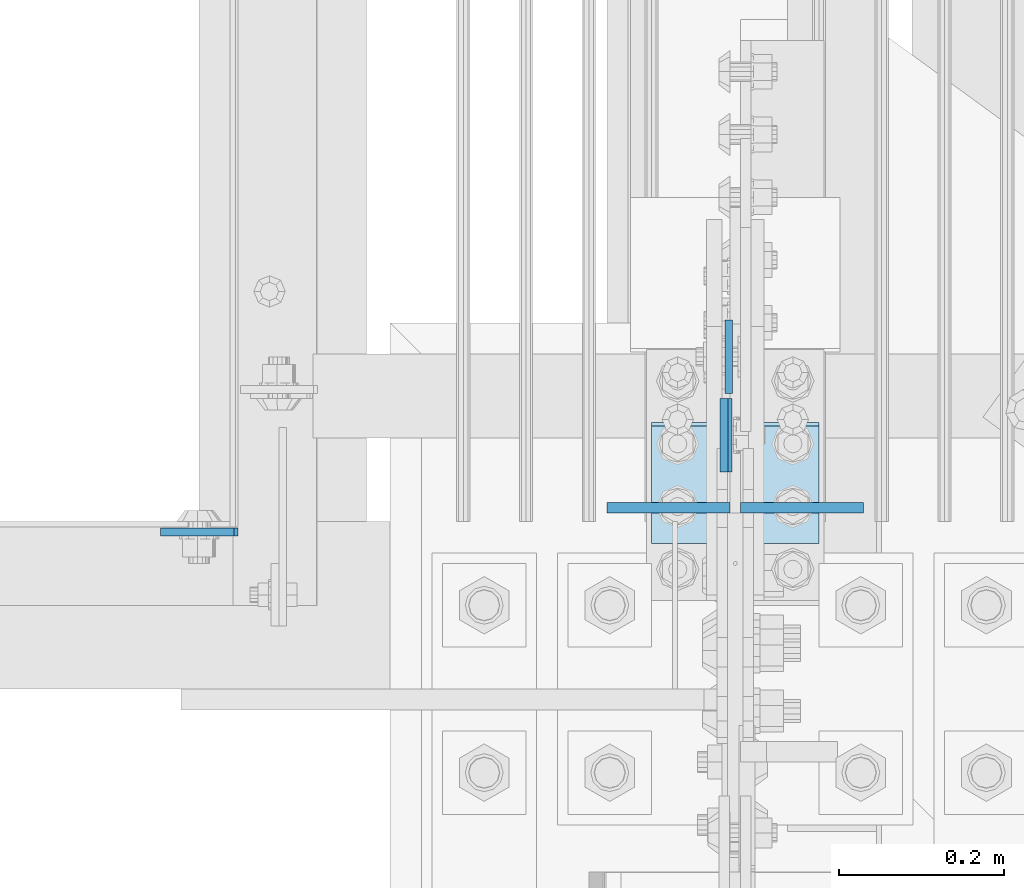
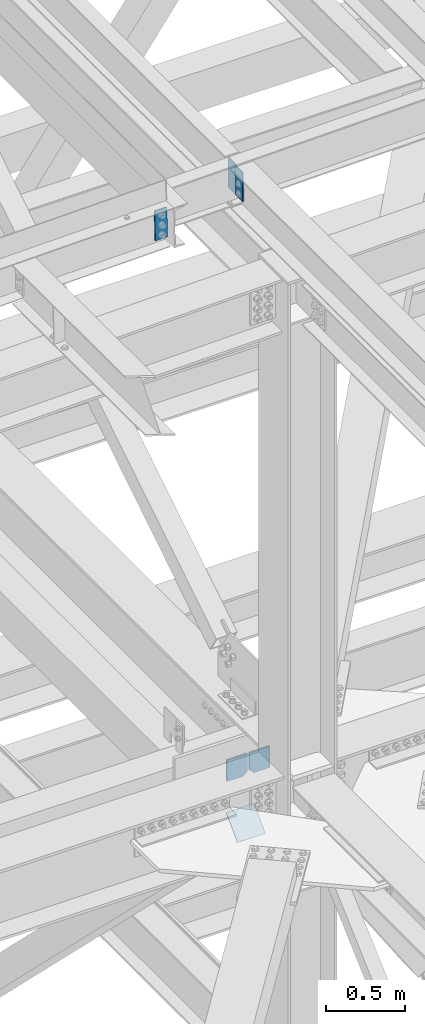
# One storey, part 3516 of 3843: 6 plates, 4 elements without a shape of their own.
"""IFC2X3 building model written with IfcOpenShell, lengths in millimetres."""

import ifcopenshell
import ifcopenshell.guid

model = None  # the IFC model being written
_history = None  # IfcOwnerHistory: only IFC2X3 demands one
_inside = {}  # id of a spatial element -> (the spatial element, [elements in it])
_under = {}  # id of a project, library or spatial element -> (it, [spatial elements below it])
_declared = {}  # id of a project -> (the project, [libraries it declares])
_typed = {}  # id of a type object -> (the type object, [elements of that type])
_made_of = {}  # id of a material, layer set ... -> (it, [elements and type objects made of it])


def new_model(schema):
    """Start an empty IFC model of exactly this schema.

    Asked for "IFC4X3", IfcOpenShell would pick the latest addendum, in which some entities
    have other attributes; the version numbers below select the first issue.
    IFC2X3 requires an IfcOwnerHistory on every rooted entity: one is made here for all.
    """
    global model, _history
    if schema == "IFC4X3":
        model = ifcopenshell.file(schema_version=(4, 3, 0, 0))
    else:
        model = ifcopenshell.file(schema=schema)
    _inside.clear()
    _under.clear()
    _declared.clear()
    _typed.clear()
    _made_of.clear()
    _history = None
    if model.schema == "IFC2X3":
        org = make("IfcOrganization", Name="unknown")
        user = make(
            "IfcPersonAndOrganization",
            ThePerson=make("IfcPerson", FamilyName="unknown"),
            TheOrganization=org,
        )
        app = make(
            "IfcApplication",
            ApplicationDeveloper=org,
            Version="unknown",
            ApplicationFullName="unknown",
            ApplicationIdentifier="unknown",
        )
        _history = make(
            "IfcOwnerHistory",
            OwningUser=user,
            OwningApplication=app,
            ChangeAction="ADDED",
            CreationDate=0,
        )
    return model


def make(cls, **values):
    """One entity of the class cls with the attributes given. An attribute that is None is left unset."""
    return model.create_entity(
        cls, **{name: value for name, value in values.items() if value is not None}
    )


def rooted(cls, **values):
    """An entity with a GlobalId (a new one), such as an element, a storey or a relation."""
    return make(cls, GlobalId=ifcopenshell.guid.new(), OwnerHistory=_history, **values)


def si_unit(unit_type, name, prefix=None):
    """IfcSIUnit, for example si_unit("LENGTHUNIT", "METRE", prefix="MILLI")."""
    return make("IfcSIUnit", UnitType=unit_type, Prefix=prefix, Name=name)


def assignment(units):
    """IfcUnitAssignment: the units of a project."""
    return None if units is None else make("IfcUnitAssignment", Units=units)


def point(xyz):
    """IfcCartesianPoint."""
    return None if xyz is None else make("IfcCartesianPoint", Coordinates=xyz)


def direction(xyz):
    """IfcDirection."""
    return None if xyz is None else make("IfcDirection", DirectionRatios=xyz)


def frame(location, z_axis=None, x_axis=None):
    """IfcAxis2Placement3D, a coordinate frame: its origin and axes. An axis left out is left unset."""
    return make(
        "IfcAxis2Placement3D",
        Location=point(location),
        Axis=direction(z_axis),
        RefDirection=direction(x_axis),
    )


def origin_with_axes():
    """The frame at (0, 0, 0) with the z axis (0, 0, 1) and the x axis (1, 0, 0) written out."""
    return frame((0.0, 0.0, 0.0), z_axis=(0.0, 0.0, 1.0), x_axis=(1.0, 0.0, 0.0))


def place(relative_to, where):
    """IfcLocalPlacement: puts the frame where relative to a parent placement (None: the world)."""
    return make(
        "IfcLocalPlacement", PlacementRelTo=relative_to, RelativePlacement=where
    )


def context(
    kind, dimensions, precision=None, world=None, true_north=None, identifier=None
):
    """IfcGeometricRepresentationContext, for example the 3D "Model" context."""
    return make(
        "IfcGeometricRepresentationContext",
        ContextIdentifier=identifier,
        ContextType=kind,
        CoordinateSpaceDimension=dimensions,
        Precision=precision,
        WorldCoordinateSystem=world,
        TrueNorth=true_north,
    )


def subcontext(parent, identifier, kind, view, scale=None):
    """IfcGeometricRepresentationSubContext, for example "Body" below "Model"."""
    return make(
        "IfcGeometricRepresentationSubContext",
        ContextIdentifier=identifier,
        ContextType=kind,
        ParentContext=parent,
        TargetScale=scale,
        TargetView=view,
    )


def project(units=None, contexts=None):
    """IfcProject with its units and contexts."""
    return rooted(
        "IfcProject",
        Name="project",
        RepresentationContexts=contexts,
        UnitsInContext=assignment(units),
    )


def spatial(cls, under=None, at=None, **own):
    """A site, building, storey or space (cls), placed at a placement, below another one or the project."""
    s = rooted(cls, ObjectPlacement=at, **own)
    if under is not None:
        _under.setdefault(under.id(), (under, []))[1].append(s)
    return s


def faces_of(points, faces, orient=None, outer=None):
    """IfcFace entities. A face is a list of loops; a loop is a list of indices into points, from 0.

    orient and outer hold one flag for each loop. By default every Orientation is true, the
    first loop of a face is its IfcFaceOuterBound and the others are IfcFaceBound.
    """
    made = []
    for i, loops in enumerate(faces):
        bounds = []
        for j, loop in enumerate(loops):
            is_outer = j == 0 if outer is None else outer[i][j]
            bounds.append(
                make(
                    "IfcFaceOuterBound" if is_outer else "IfcFaceBound",
                    Bound=make("IfcPolyLoop", Polygon=[points[k] for k in loop]),
                    Orientation=True if orient is None else orient[i][j],
                )
            )
        made.append(make("IfcFace", Bounds=bounds))
    return made


def faceted_brep(points, faces, orient=None, outer=None, voids=None):
    """IfcFacetedBrep: a solid bounded by flat faces; with voids (closed shells), ...WithVoids."""
    shared = [point(p) for p in points]
    hull = make("IfcClosedShell", CfsFaces=faces_of(shared, faces, orient, outer))
    if voids is None:
        return make("IfcFacetedBrep", Outer=hull)
    return make(
        "IfcFacetedBrepWithVoids",
        Outer=hull,
        Voids=[
            make(cls, CfsFaces=faces_of(shared, fs, o, b)) for cls, fs, o, b in voids
        ],
    )


def shape(context_of_items, identifier, shape_type, items):
    """IfcShapeRepresentation: the items that make up one representation, for example the "Body"."""
    return make(
        "IfcShapeRepresentation",
        ContextOfItems=context_of_items,
        RepresentationIdentifier=identifier,
        RepresentationType=shape_type,
        Items=items,
    )


def material(Name=None, Category=None):
    """IfcMaterial."""
    return make("IfcMaterial", Name=Name, Category=Category)


def made_of(thing, what):
    """Note that an element or type object is made of a material, layer set ...; save() writes the relation."""
    if what is not None:
        _made_of.setdefault(what.id(), (what, []))[1].append(thing)
    return thing


def type_object(cls, material=None, **own):
    """A type object (cls), such as IfcWallType, which elements share."""
    return made_of(rooted(cls, **own), material)


def element(
    cls,
    number,
    at=None,
    inside=None,
    cuts=None,
    type_object=None,
    material=None,
    context=None,
    identifier="Body",
    shape_type=None,
    held_by="IfcProductDefinitionShape",
    body=None,
    shapes=None,
    **own,
):
    """One element of the class cls, such as IfcWall. Its Tag is "e" and its number.

    at: its placement. inside: the storey or other place that contains it. cuts: it is an
    opening in that element (IfcRelVoidsElement). A single representation is given by context,
    identifier, shape_type and body (its items); several are given by shapes. held_by: the class
    of the entity that holds the representations. save() writes the other relations.
    """
    e = rooted(cls, Tag="e%d" % number, ObjectPlacement=at, **own)
    if body is not None:
        shapes = [shape(context, identifier, shape_type, body)]
    if shapes is not None:
        e.Representation = make(held_by, Representations=shapes)
    if inside is not None:
        _inside.setdefault(inside.id(), (inside, []))[1].append(e)
    if cuts is not None:
        rooted(
            "IfcRelVoidsElement", RelatingBuildingElement=cuts, RelatedOpeningElement=e
        )
    if type_object is not None:
        _typed.setdefault(type_object.id(), (type_object, []))[1].append(e)
    return made_of(e, material)


def aggregate(whole, parts):
    """IfcRelAggregates: a whole, such as a stair, and the parts it consists of."""
    return rooted("IfcRelAggregates", RelatingObject=whole, RelatedObjects=parts)


def save(model, path):
    """Write the relations noted so far, then the file.

    IfcRelAggregates (storeys below a building ...), IfcRelContainedInSpatialStructure (elements
    in a storey), IfcRelDefinesByType, IfcRelAssociatesMaterial and IfcRelDeclares: one each for
    every whole, place, type object, material and project.
    """
    for whole, parts in _under.values():
        aggregate(whole, parts)
    for where, things in _inside.values():
        rooted(
            "IfcRelContainedInSpatialStructure",
            RelatedElements=things,
            RelatingStructure=where,
        )
    for kind, things in _typed.values():
        rooted("IfcRelDefinesByType", RelatedObjects=things, RelatingType=kind)
    for what, things in _made_of.values():
        rooted("IfcRelAssociatesMaterial", RelatedObjects=things, RelatingMaterial=what)
    for by, libraries in _declared.values():
        rooted("IfcRelDeclares", RelatingContext=by, RelatedDefinitions=libraries)
    model.write(path)


model = new_model("IFC2X3")

# Units and contexts
model_context = context("Model", 3, precision=1e-05, world=origin_with_axes())
body_context = subcontext(model_context, "Body", "Model", "MODEL_VIEW")
ifc_project = project(units=[si_unit("LENGTHUNIT", "METRE", prefix="MILLI"), si_unit("AREAUNIT", "SQUARE_METRE"), si_unit("VOLUMEUNIT", "CUBIC_METRE"), si_unit("MASSUNIT", "GRAM", prefix="KILO"), si_unit("TIMEUNIT", "SECOND"), si_unit("PLANEANGLEUNIT", "RADIAN"), si_unit("SOLIDANGLEUNIT", "STERADIAN"), si_unit("THERMODYNAMICTEMPERATUREUNIT", "DEGREE_CELSIUS"), si_unit("LUMINOUSINTENSITYUNIT", "LUMEN")], contexts=[model_context])

# Site, building, storey
site_placement = place(None, origin_with_axes())
site = spatial("IfcSite", under=ifc_project, at=site_placement, CompositionType="ELEMENT")
building_placement = place(site_placement, origin_with_axes())
building = spatial("IfcBuilding", under=site, at=building_placement, Name="Undefined", CompositionType="ELEMENT")
storey_placement = place(building_placement, origin_with_axes())
storey = spatial("IfcBuildingStorey", under=building, at=storey_placement, Name="Undefined", CompositionType="ELEMENT", Elevation=0.0)

# Assembly, plate
assembly_1_placement = place(storey_placement, origin_with_axes())
assembly_1 = element("IfcElementAssembly", 1, at=assembly_1_placement, inside=storey, Name="CHANNEL", AssemblyPlace="NOTDEFINED", PredefinedType="RIGID_FRAME")
ifc_material_1 = material(Name="STEEL/A572-50")
plate_type_1 = type_object("IfcPlateType", PredefinedType="NOTDEFINED")
plate_1_placement = place(assembly_1_placement, frame((76404.0058949781, 92811.5999973788, 46534.1205099336), z_axis=(-0.999776270257024, 0.0, -0.0211520550054595), x_axis=(0.0211520550054438, 0.0, -0.999776270257025)))
plate_1 = element("IfcPlate", 2, at=plate_1_placement, type_object=plate_type_1, material=ifc_material_1, Name="PLATE", context=body_context, shape_type="Brep", body=[
    faceted_brep([(0.0, -4.76249999999709, 0.0), (0.0, -4.76249999999709, 88.9000015258789), (0.0, 4.76249999999709, 88.9000015258789), (0.0, 4.76249999999709, 0.0), (228.600006102781, -4.7625000004191, 88.9000015257589), (228.600006102781, 4.76249999954598, 88.9000015257443), (228.600006103079, -4.7625000004482, 7.27595761418343e-12), (228.600006103079, 4.76249999954598, -7.27595761418343e-12)], [[[0, 1, 2, 3]], [[1, 4, 5, 2]], [[4, 6, 7, 5]], [[6, 0, 3, 7]], [[5, 7, 3, 2]], [[6, 4, 1, 0]]]),
])
aggregate(assembly_1, [plate_1])

# Assembly, plates
assembly_2_placement = place(storey_placement, origin_with_axes())
assembly_2 = element("IfcElementAssembly", 3, at=assembly_2_placement, inside=storey, Name="BEAM", AssemblyPlace="NOTDEFINED", PredefinedType="RIGID_FRAME")
plate_2_placement = place(assembly_2_placement, frame((76999.0866551512, 92973.5247811047, 46546.7869799015), z_axis=(4.59499967400918e-05, -0.999999998943826, 9.72154033661359e-07), x_axis=(0.0211520550054438, 0.0, -0.999776270257025)))
plate_2 = element("IfcPlate", 4, at=plate_2_placement, type_object=plate_type_1, material=ifc_material_1, Name="PLATE", context=body_context, shape_type="Brep", body=[
    faceted_brep([(0.0, -4.76249999999709, 0.0), (0.0, -4.76249999999709, 88.9000015258789), (0.0, 4.76249999999709, 88.9000015258789), (0.0, 4.76249999999709, 0.0), (228.600006102781, -4.7625000004191, 88.9000015257589), (228.600006102781, 4.76249999954598, 88.9000015257443), (228.600006103079, -4.7625000004482, 7.27595761418343e-12), (228.600006103079, 4.76249999954598, -7.27595761418343e-12)], [[[0, 1, 2, 3]], [[1, 4, 5, 2]], [[4, 6, 7, 5]], [[6, 0, 3, 7]], [[5, 7, 3, 2]], [[6, 4, 1, 0]]]),
])
plate_3_placement = place(assembly_2_placement, frame((77004.8624999969, 92979.875, 46547.0091933511), z_axis=(0.0, 1.0, 0.0), x_axis=(0.0, 0.0, -1.0)))
plate_3 = element("IfcPlate", 5, at=plate_3_placement, type_object=plate_type_1, material=ifc_material_1, Name="PLATE", context=body_context, shape_type="Brep", body=[
    faceted_brep([(0.0, -4.76249999999709, 0.0), (0.0, -4.76249999999709, 88.9000015258789), (0.0, 4.76249999999709, 88.9000015258789), (0.0, 4.76249999999709, 0.0), (228.600006102781, -4.7625000004191, 88.9000015257589), (228.600006102781, 4.76249999954598, 88.9000015257443), (228.600006103079, -4.7625000004482, 7.27595761418343e-12), (228.600006103079, 4.76249999954598, -7.27595761418343e-12)], [[[0, 1, 2, 3]], [[1, 4, 5, 2]], [[4, 6, 7, 5]], [[6, 0, 3, 7]], [[5, 7, 3, 2]], [[6, 4, 1, 0]]]),
])
aggregate(assembly_2, [plate_2, plate_3])

assembly_3_placement = place(storey_placement, origin_with_axes())
assembly_3 = element("IfcElementAssembly", 6, at=assembly_3_placement, inside=storey, Name="BEAM", AssemblyPlace="NOTDEFINED", PredefinedType="RIGID_FRAME")
plate_type_2 = type_object("IfcPlateType", PredefinedType="NOTDEFINED")
plate_4_placement = place(assembly_3_placement, frame((77019.15, 92841.0670207929, 42110.025), z_axis=(0.0, 0.0, -1.0), x_axis=(1.0, 0.0, 0.0)))
plate_4 = element("IfcPlate", 7, at=plate_4_placement, type_object=plate_type_2, material=ifc_material_1, Name="PLATE", context=body_context, shape_type="Brep", body=[
    faceted_brep([(0.0, -6.3499999046162, 0.0), (0.0, -6.35000000000582, 131.762499999997), (0.0, 6.35000000000582, 131.762499999997), (7.27595761418343e-12, 6.3499999046162, 0.0), (31.75, -6.35000000000582, 163.512499999997), (31.75, 6.35000000000582, 163.512499999997), (149.224999999991, -6.35000000000582, 163.512499999997), (149.224999999991, 6.35000000000582, 163.512499999997), (149.224999999991, -6.35000000000582, 0.0), (149.224999999991, 6.35000000000582, 0.0)], [[[0, 1, 2, 3]], [[1, 4, 5, 2]], [[4, 6, 7, 5]], [[6, 8, 9, 7]], [[8, 0, 3, 9]], [[5, 7, 9, 3, 2]], [[8, 6, 4, 1, 0]]]),
])
plate_5_placement = place(assembly_3_placement, frame((76857.225, 92841.0670207929, 42110.025), z_axis=(0.0, 0.0, -1.0), x_axis=(1.0, 0.0, 0.0)))
plate_5 = element("IfcPlate", 8, at=plate_5_placement, type_object=plate_type_2, material=ifc_material_1, Name="PLATE", context=body_context, shape_type="Brep", body=[
    faceted_brep([(0.0, -6.3499999046162, 0.0), (0.0, -6.34999999999854, 163.512499999997), (0.0, 6.34999999999854, 163.512499999997), (7.27595761418343e-12, 6.3499999046162, 0.0), (117.474999999991, -6.34999999999854, 163.512499999997), (117.474999999991, 6.34999999999854, 163.512499999997), (149.224999999991, -6.34999999999854, 131.762499999997), (149.224999999991, 6.34999999999854, 131.762499999997), (149.224999999991, -6.35000000000582, 0.0), (149.224999999991, 6.35000000000582, 0.0)], [[[0, 1, 2, 3]], [[1, 4, 5, 2]], [[4, 6, 7, 5]], [[6, 8, 9, 7]], [[8, 0, 3, 9]], [[5, 7, 9, 3, 2]], [[8, 6, 4, 1, 0]]]),
])
aggregate(assembly_3, [plate_4, plate_5])

# Assembly, plate
assembly_4_placement = place(storey_placement, origin_with_axes())
assembly_4 = element("IfcElementAssembly", 9, at=assembly_4_placement, inside=storey, Name="Plate", AssemblyPlace="NOTDEFINED", PredefinedType="RIGID_FRAME")
ifc_material_2 = material(Name="STEEL/A36")
plate_type_3 = type_object("IfcPlateType", PredefinedType="NOTDEFINED")
plate_6_placement = place(assembly_4_placement, frame((76911.2, 92799.9209990712, 41479.0745012374), z_axis=(0.0, 0.701307718956815, 0.712858669956107), x_axis=(1.0, 0.0, 0.0)))
plate_6 = element("IfcPlate", 10, at=plate_6_placement, type_object=plate_type_3, material=ifc_material_2, Name="Plate", context=body_context, shape_type="Brep", body=[
    faceted_brep([(0.0, -3.17499999999927, 0.0), (0.0, -3.17500000043947, 203.200000001736), (0.0, 3.1749999995518, 203.200000001743), (0.0, 3.17499999999927, 0.0), (203.200000000012, -3.17500000043947, 203.200000001736), (203.200000000012, 3.1749999995518, 203.200000001743), (203.199996948242, -3.17499999999927, 0.0), (203.199996948242, 3.17499999999927, 0.0)], [[[0, 1, 2, 3]], [[1, 4, 5, 2]], [[4, 6, 7, 5]], [[6, 0, 3, 7]], [[5, 7, 3, 2]], [[6, 4, 1, 0]]]),
])
aggregate(assembly_4, [plate_6])

save(model, "model.ifc")
